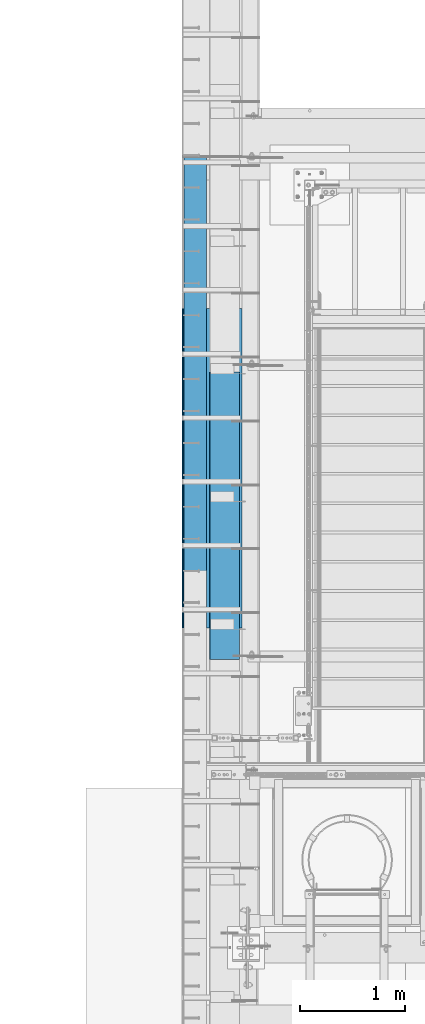
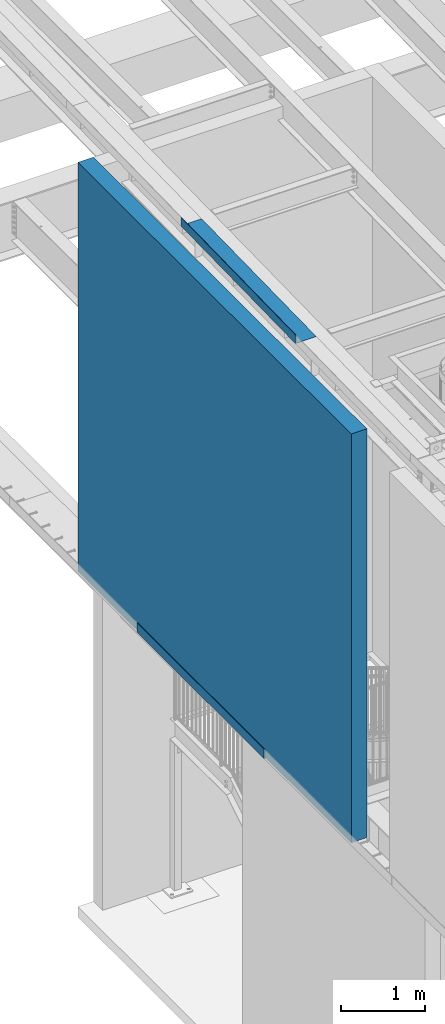
# One storey, part 1089 of 1763: 3 beams, 3 elements without a shape of their own.
"""IFC2X3 building model written with IfcOpenShell, lengths in millimetres."""

from ifc_helpers import new_model, si_unit, frame, origin_with_axes, place, context, subcontext, project, spatial, faceted_brep, material, type_object, element, aggregate, save


model = new_model("IFC2X3")

# Units and contexts
model_context = context("Model", 3, precision=1e-05, world=origin_with_axes())
body_context = subcontext(model_context, "Body", "Model", "MODEL_VIEW")
ifc_project = project(units=[si_unit("LENGTHUNIT", "METRE", prefix="MILLI"), si_unit("AREAUNIT", "SQUARE_METRE"), si_unit("VOLUMEUNIT", "CUBIC_METRE"), si_unit("MASSUNIT", "GRAM", prefix="KILO"), si_unit("TIMEUNIT", "SECOND"), si_unit("PLANEANGLEUNIT", "RADIAN"), si_unit("SOLIDANGLEUNIT", "STERADIAN"), si_unit("THERMODYNAMICTEMPERATUREUNIT", "DEGREE_CELSIUS"), si_unit("LUMINOUSINTENSITYUNIT", "LUMEN")], contexts=[model_context])

# Site, building, storey
site_placement = place(None, origin_with_axes())
site = spatial("IfcSite", under=ifc_project, at=site_placement, CompositionType="ELEMENT")
building_placement = place(site_placement, origin_with_axes())
building = spatial("IfcBuilding", under=site, at=building_placement, Name="Undefined", CompositionType="ELEMENT")
storey_placement = place(building_placement, origin_with_axes())
storey = spatial("IfcBuildingStorey", under=building, at=storey_placement, Name="Undefined", CompositionType="ELEMENT", Elevation=0.0)

# Assembly, beam
assembly_1_placement = place(storey_placement, origin_with_axes())
assembly_1 = element("IfcElementAssembly", 1, at=assembly_1_placement, inside=storey, Name="WALL", AssemblyPlace="NOTDEFINED", PredefinedType="REINFORCEMENT_UNIT")
ifc_material_1 = material(Name="CONCRETE/5000")
beam_type_1 = type_object("IfcBeamType", PredefinedType="NOTDEFINED")
beam_1_placement = place(assembly_1_placement, frame((-87858.0372736983, 31022.9250061035, 8189.9125), z_axis=(-1.0, 0.0, 0.0), x_axis=(0.0, 1.0, 0.0)))
beam_1 = element("IfcBeam", 2, at=beam_1_placement, type_object=beam_type_1, material=ifc_material_1, Name="WALL", context=body_context, shape_type="Brep", body=[
    faceted_brep([(0.0, 2986.0875, -107.949999999997), (0.0, 2986.0875, 107.949999999997), (6543.6749938965, 2986.0875, 107.949999999997), (6543.6749938965, 2986.0875, -107.949999999997), (0.0, -2986.0875, 107.949999999997), (6543.6749938965, -2986.0875, 107.949999999997), (0.0, -2986.0875, -107.949999999997), (6543.6749938965, -2986.0875, -107.949999999997)], [[[0, 1, 2, 3]], [[1, 4, 5, 2]], [[4, 6, 7, 5]], [[6, 0, 3, 7]], [[5, 7, 3, 2]], [[6, 4, 1, 0]]]),
])
aggregate(assembly_1, [beam_1])

assembly_2_placement = place(storey_placement, origin_with_axes())
assembly_2 = element("IfcElementAssembly", 3, at=assembly_2_placement, inside=storey, Name="BEAM", AssemblyPlace="NOTDEFINED", PredefinedType="RIGID_FRAME")
ifc_material_2 = material(Name="STEEL/A36")
beam_type_2 = type_object("IfcBeamType", PredefinedType="NOTDEFINED")
beam_2_placement = place(assembly_2_placement, frame((-87413.5372736984, 34597.9755, 5199.0625), z_axis=(0.0, -1.0, 0.0), x_axis=(-1.0, 0.0, 0.0)))
beam_2 = element("IfcBeam", 4, at=beam_2_placement, type_object=beam_type_2, material=ifc_material_2, Name="BENT_PLATE", context=body_context, shape_type="Brep", body=[
    faceted_brep([(0.0, -4.76249999999982, -1524.0), (0.0, -4.76249999999982, 1524.0), (0.0, 4.76249999999982, 1524.0), (0.0, 4.76249999999982, -1524.0), (571.5, 4.76249999999982, 1524.0), (571.5, 4.76249999999982, -1524.0), (561.975000000006, -4.76249999999982, -1524.0), (561.975000000006, -4.76249999999982, 1524.0), (571.5, -134.937496948242, 1524.0), (571.5, -134.937496948242, -1524.0), (561.975000000006, -134.937496948242, 1524.0), (561.975000000006, -134.937496948242, -1524.0)], [[[0, 1, 2, 3]], [[3, 2, 4, 5]], [[1, 0, 6, 7]], [[5, 4, 8, 9]], [[4, 2, 1, 7, 10, 8]], [[7, 6, 11, 10]], [[6, 0, 3, 5, 9, 11]], [[10, 11, 9, 8]]]),
])
aggregate(assembly_2, [beam_2])

assembly_3_placement = place(storey_placement, origin_with_axes())
assembly_3 = element("IfcElementAssembly", 5, at=assembly_3_placement, inside=storey, Name="BEAM", AssemblyPlace="NOTDEFINED", PredefinedType="RIGID_FRAME")
beam_type_3 = type_object("IfcBeamType", PredefinedType="NOTDEFINED")
beam_3_placement = place(assembly_3_placement, frame((-87438.9372736983, 34144.7738671464, 11378.7578958722), z_axis=(0.0, -0.999786037781472, -0.0206852279954809), x_axis=(-1.0, 0.0, 0.0)))
beam_3 = element("IfcBeam", 6, at=beam_3_placement, type_object=beam_type_3, material=ifc_material_2, Name="BENT_PLATE", context=body_context, shape_type="Brep", body=[
    faceted_brep([(2.91038304567337e-11, -3.17499999963729, -1371.60000000396), (-2.91038304567337e-11, -3.17500000036489, 1371.60000000395), (-2.91038304567337e-11, 3.17499999963184, 1371.60000000395), (2.91038304567337e-11, 3.17500000035943, -1371.60000000396), (285.75000000016, 3.17499999930078, 1371.59999999897), (285.750000000276, 3.17499999982283, -1371.59999999897), (279.400000000271, -3.1750000001648, -1371.59999999897), (279.400000000154, -3.17500000068321, 1371.59999999897), (285.750000000218, -123.824997298658, 1371.59999999895), (285.750000000218, -123.824997298212, -1371.59999999898), (279.400000000212, -123.824997298658, 1371.59999999895), (279.400000000212, -123.824997298212, -1371.59999999898)], [[[0, 1, 2, 3]], [[3, 2, 4, 5]], [[1, 0, 6, 7]], [[5, 4, 8, 9]], [[4, 2, 1, 7, 10, 8]], [[7, 6, 11, 10]], [[6, 0, 3, 5, 9, 11]], [[10, 11, 9, 8]]]),
])
aggregate(assembly_3, [beam_3])

save(model, "model.ifc")
